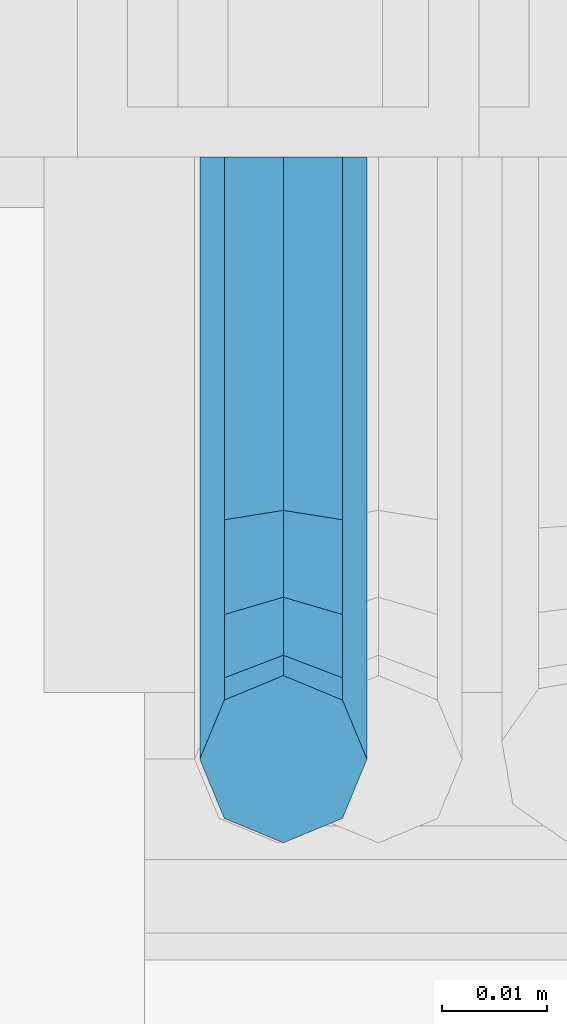
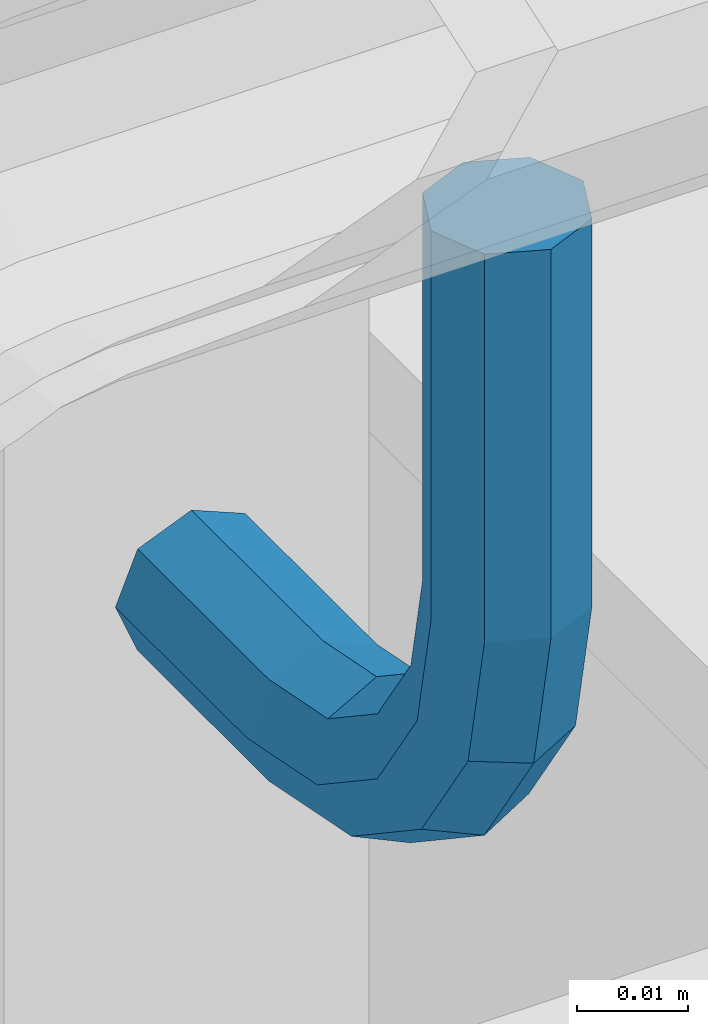
# One storey, part 1203 of 1876: 1 beam, 1 element without a shape of its own.
"""IFC2X3 building model written with IfcOpenShell, lengths in millimetres."""

from ifc_helpers import new_model, si_unit, frame, origin_with_axes, place, context, subcontext, project, spatial, faceted_brep, material, type_object, element, aggregate, save


model = new_model("IFC2X3")

# Units and contexts
model_context = context("Model", 3, precision=1e-05, world=origin_with_axes())
body_context = subcontext(model_context, "Body", "Model", "MODEL_VIEW")
ifc_project = project(units=[si_unit("LENGTHUNIT", "METRE", prefix="MILLI"), si_unit("AREAUNIT", "SQUARE_METRE"), si_unit("VOLUMEUNIT", "CUBIC_METRE"), si_unit("MASSUNIT", "GRAM", prefix="KILO"), si_unit("TIMEUNIT", "SECOND"), si_unit("PLANEANGLEUNIT", "RADIAN"), si_unit("SOLIDANGLEUNIT", "STERADIAN"), si_unit("THERMODYNAMICTEMPERATUREUNIT", "DEGREE_CELSIUS"), si_unit("LUMINOUSINTENSITYUNIT", "LUMEN")], contexts=[model_context])

# Site, building, storey
site_placement = place(None, origin_with_axes())
site = spatial("IfcSite", under=ifc_project, at=site_placement, CompositionType="ELEMENT")
building_placement = place(site_placement, origin_with_axes())
building = spatial("IfcBuilding", under=site, at=building_placement, Name="Undefined", CompositionType="ELEMENT")
storey_placement = place(building_placement, origin_with_axes())
storey = spatial("IfcBuildingStorey", under=building, at=storey_placement, Name="Undefined", CompositionType="ELEMENT", Elevation=0.0)

# Assembly, beam
assembly_placement = place(storey_placement, origin_with_axes())
assembly = element("IfcElementAssembly", 1, at=assembly_placement, inside=storey, Name="RAIL", AssemblyPlace="NOTDEFINED", PredefinedType="RIGID_FRAME")
ifc_material = material(Name="STEEL/A36")
beam_type = type_object("IfcBeamType", PredefinedType="NOTDEFINED")
beam_placement = place(assembly_placement, frame((6137.76607495183, -4800.60000114554, 18802.35), z_axis=(-1.0, 0.0, 0.0), x_axis=(0.0, -1.0, 0.0)))
beam = element("IfcBeam", 2, at=beam_placement, type_object=beam_type, material=ifc_material, Name="BRACKET", context=body_context, shape_type="Brep", body=[
    faceted_brep([(0.0, -7.9375, 0.0), (0.0, -5.61266007566822, -5.61266007566883), (23.8125, -5.61266007566883, -5.61266007566792), (23.8125, -7.9375, 0.0), (0.0, 0.0, -7.9375), (23.8125, 0.0, -7.9375), (0.0, 5.61266007566822, -5.61266007566883), (23.8125, 5.61266007566883, -5.61266007566792), (0.0, 7.9375, 0.0), (23.8125, 7.9375, 0.0), (0.0, 5.61266007566822, 5.61266007566883), (23.8125, 5.61266007566883, 5.61266007566792), (0.0, 0.0, 7.9375), (23.8125, 0.0, 7.9375), (0.0, -5.61266007566822, 5.61266007566883), (23.8125, -5.61266007566883, 5.61266007566792), (39.6077592547981, -4.79562758825341, 0.0), (38.7180815328556, -2.64775556579843, 5.61266007566792), (36.5702095103998, 2.53766620105671, 7.9375), (34.4223374879448, 7.72308796790821, 5.61266007566792), (33.5326597660023, 9.87095999036319, 0.0), (34.4223374879448, 7.72308796790821, -5.61266007566792), (36.5702095103998, 2.53766620105671, -7.9375), (38.7180815328556, -2.64775556579843, -5.61266007566792), (51.3544233967659, 5.79557812911298, -5.61266007566792), (52.9983334724348, 4.15166805344415, 0.0), (47.3856733967659, 9.76432812911298, -7.9375), (43.4169233967659, 13.733078129113, -5.61266007566792), (41.773013321098, 15.3769882047818, 0.0), (43.4169233967659, 13.733078129113, 5.61266007566792), (47.3856733967659, 9.76432812911298, 7.9375), (51.3544233967659, 5.79557812911298, 5.61266007566792), (59.7977570916764, 18.4319199930251, -5.61266007566792), (61.9456291141314, 17.5422422710835, 0.0), (54.6123353248231, 20.5797920154801, -7.9375), (49.4269135579698, 22.727664037935, -5.61266007566792), (47.2790415355148, 23.6173417598766, 0.0), (49.4269135579698, 22.727664037935, 5.61266007566792), (54.6123353248231, 20.5797920154801, 7.9375), (59.7977570916764, 18.4319199930251, 5.61266007566792), (62.7626616015468, 33.3375015258789, -5.61266007566792), (65.0875015258789, 33.3375015258789, 0.0), (57.1500015258789, 33.3375015258789, -7.9375), (51.5373414502101, 33.3375015258789, -5.61266007566792), (49.2125015258789, 33.3375015258789, 0.0), (51.5373414502101, 33.3375015258789, 5.61266007566792), (57.1500015258789, 33.3375015258789, 7.9375), (62.7626616015468, 33.3375015258789, 5.61266007566792), (62.7626616015468, 76.1999969482422, -5.61266007566792), (65.0875015258789, 76.1999969482422, 0.0), (57.1500015258789, 76.1999969482422, -7.9375), (51.537341450211, 76.1999969482422, -5.61266007566792), (49.2125015258789, 76.1999969482422, 0.0), (51.537341450211, 76.1999969482422, 5.61266007566792), (57.1500015258789, 76.1999969482422, 7.9375), (62.7626616015468, 76.1999969482422, 5.61266007566792)], [[[0, 1, 2, 3]], [[1, 4, 5, 2]], [[4, 6, 7, 5]], [[6, 8, 9, 7]], [[8, 10, 11, 9]], [[10, 12, 13, 11]], [[12, 14, 15, 13]], [[14, 0, 3, 15]], [[14, 12, 10, 8, 6, 4, 1, 0]], [[15, 3, 16, 17]], [[13, 15, 17, 18]], [[11, 13, 18, 19]], [[9, 11, 19, 20]], [[7, 9, 20, 21]], [[5, 7, 21, 22]], [[2, 5, 22, 23]], [[3, 2, 23, 16]], [[23, 24, 25, 16]], [[22, 26, 24, 23]], [[21, 27, 26, 22]], [[20, 28, 27, 21]], [[19, 29, 28, 20]], [[18, 30, 29, 19]], [[17, 31, 30, 18]], [[16, 25, 31, 17]], [[24, 32, 33, 25]], [[26, 34, 32, 24]], [[27, 35, 34, 26]], [[28, 36, 35, 27]], [[29, 37, 36, 28]], [[30, 38, 37, 29]], [[31, 39, 38, 30]], [[25, 33, 39, 31]], [[32, 40, 41, 33]], [[34, 42, 40, 32]], [[35, 43, 42, 34]], [[36, 44, 43, 35]], [[37, 45, 44, 36]], [[38, 46, 45, 37]], [[39, 47, 46, 38]], [[33, 41, 47, 39]], [[41, 40, 48, 49]], [[40, 42, 50, 48]], [[42, 43, 51, 50]], [[43, 44, 52, 51]], [[44, 45, 53, 52]], [[45, 46, 54, 53]], [[46, 47, 55, 54]], [[47, 41, 49, 55]], [[50, 51, 52, 53, 54, 55, 49, 48]]]),
])
aggregate(assembly, [beam])

save(model, "model.ifc")
